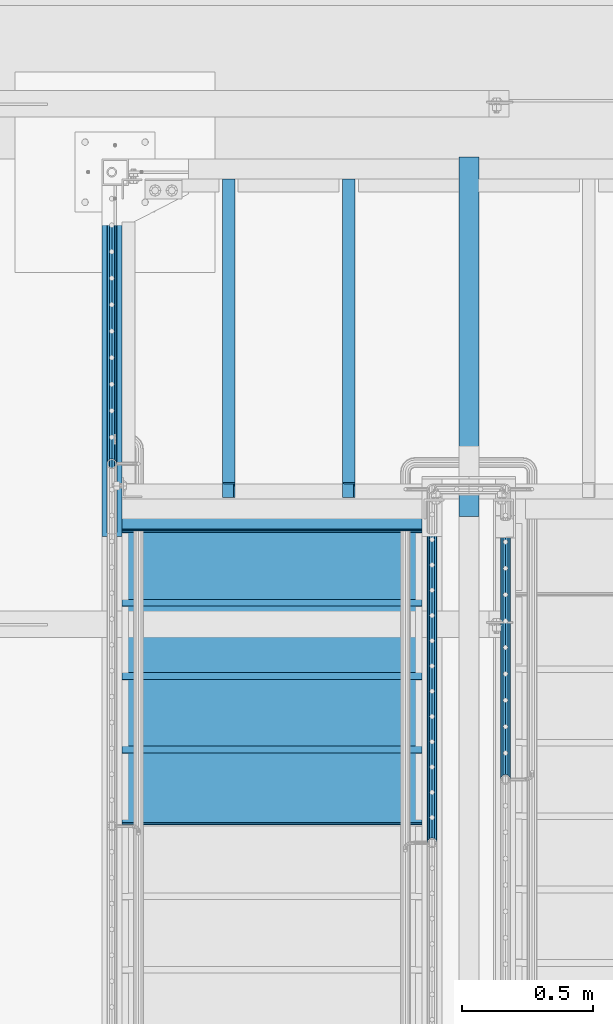
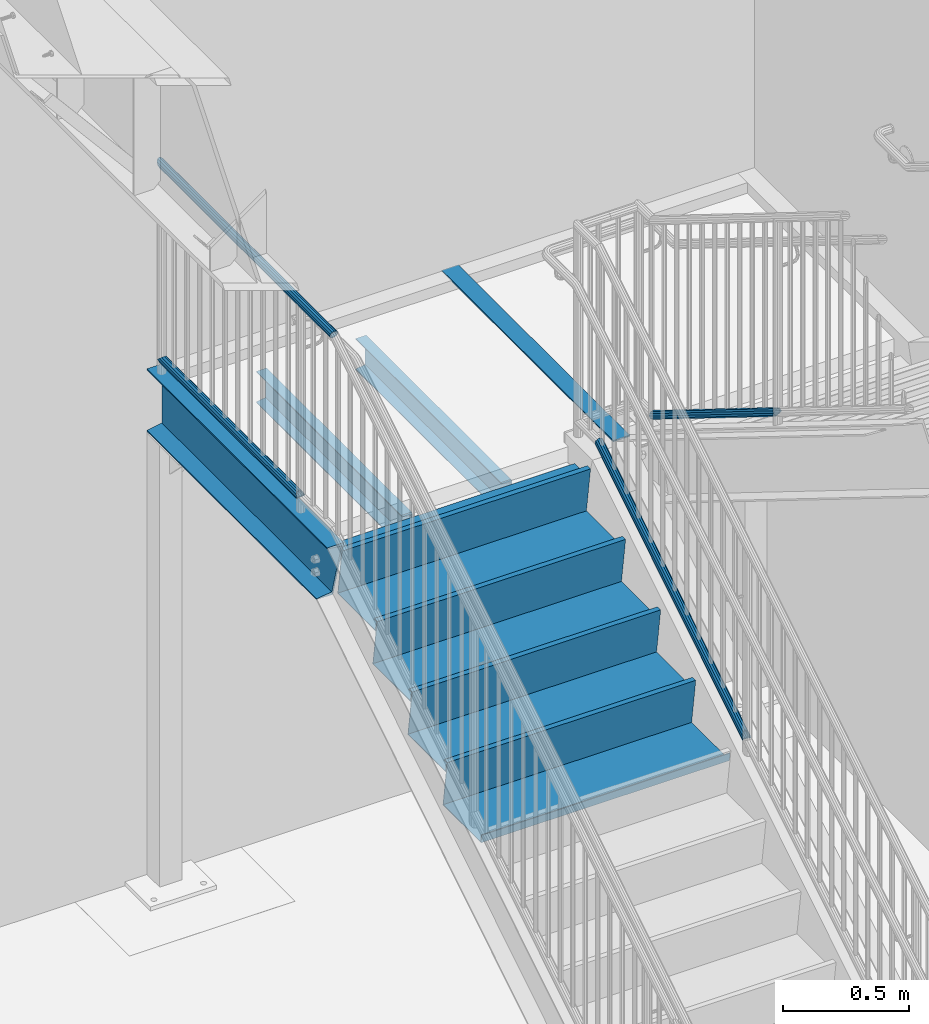
# One storey, part 1092 of 1763: 11 beams, 2 members, 6 elements without a shape of their own.
"""IFC2X3 building model written with IfcOpenShell, lengths in millimetres."""

import ifcopenshell
import ifcopenshell.guid

model = None  # the IFC model being written
_history = None  # IfcOwnerHistory: only IFC2X3 demands one
_inside = {}  # id of a spatial element -> (the spatial element, [elements in it])
_under = {}  # id of a project, library or spatial element -> (it, [spatial elements below it])
_declared = {}  # id of a project -> (the project, [libraries it declares])
_typed = {}  # id of a type object -> (the type object, [elements of that type])
_made_of = {}  # id of a material, layer set ... -> (it, [elements and type objects made of it])


def new_model(schema):
    """Start an empty IFC model of exactly this schema.

    Asked for "IFC4X3", IfcOpenShell would pick the latest addendum, in which some entities
    have other attributes; the version numbers below select the first issue.
    IFC2X3 requires an IfcOwnerHistory on every rooted entity: one is made here for all.
    """
    global model, _history
    if schema == "IFC4X3":
        model = ifcopenshell.file(schema_version=(4, 3, 0, 0))
    else:
        model = ifcopenshell.file(schema=schema)
    _inside.clear()
    _under.clear()
    _declared.clear()
    _typed.clear()
    _made_of.clear()
    _history = None
    if model.schema == "IFC2X3":
        org = make("IfcOrganization", Name="unknown")
        user = make(
            "IfcPersonAndOrganization",
            ThePerson=make("IfcPerson", FamilyName="unknown"),
            TheOrganization=org,
        )
        app = make(
            "IfcApplication",
            ApplicationDeveloper=org,
            Version="unknown",
            ApplicationFullName="unknown",
            ApplicationIdentifier="unknown",
        )
        _history = make(
            "IfcOwnerHistory",
            OwningUser=user,
            OwningApplication=app,
            ChangeAction="ADDED",
            CreationDate=0,
        )
    return model


def make(cls, **values):
    """One entity of the class cls with the attributes given. An attribute that is None is left unset."""
    return model.create_entity(
        cls, **{name: value for name, value in values.items() if value is not None}
    )


def rooted(cls, **values):
    """An entity with a GlobalId (a new one), such as an element, a storey or a relation."""
    return make(cls, GlobalId=ifcopenshell.guid.new(), OwnerHistory=_history, **values)


def si_unit(unit_type, name, prefix=None):
    """IfcSIUnit, for example si_unit("LENGTHUNIT", "METRE", prefix="MILLI")."""
    return make("IfcSIUnit", UnitType=unit_type, Prefix=prefix, Name=name)


def assignment(units):
    """IfcUnitAssignment: the units of a project."""
    return None if units is None else make("IfcUnitAssignment", Units=units)


def point(xyz):
    """IfcCartesianPoint."""
    return None if xyz is None else make("IfcCartesianPoint", Coordinates=xyz)


def direction(xyz):
    """IfcDirection."""
    return None if xyz is None else make("IfcDirection", DirectionRatios=xyz)


def frame(location, z_axis=None, x_axis=None):
    """IfcAxis2Placement3D, a coordinate frame: its origin and axes. An axis left out is left unset."""
    return make(
        "IfcAxis2Placement3D",
        Location=point(location),
        Axis=direction(z_axis),
        RefDirection=direction(x_axis),
    )


def origin_with_axes():
    """The frame at (0, 0, 0) with the z axis (0, 0, 1) and the x axis (1, 0, 0) written out."""
    return frame((0.0, 0.0, 0.0), z_axis=(0.0, 0.0, 1.0), x_axis=(1.0, 0.0, 0.0))


def place(relative_to, where):
    """IfcLocalPlacement: puts the frame where relative to a parent placement (None: the world)."""
    return make(
        "IfcLocalPlacement", PlacementRelTo=relative_to, RelativePlacement=where
    )


def context(
    kind, dimensions, precision=None, world=None, true_north=None, identifier=None
):
    """IfcGeometricRepresentationContext, for example the 3D "Model" context."""
    return make(
        "IfcGeometricRepresentationContext",
        ContextIdentifier=identifier,
        ContextType=kind,
        CoordinateSpaceDimension=dimensions,
        Precision=precision,
        WorldCoordinateSystem=world,
        TrueNorth=true_north,
    )


def subcontext(parent, identifier, kind, view, scale=None):
    """IfcGeometricRepresentationSubContext, for example "Body" below "Model"."""
    return make(
        "IfcGeometricRepresentationSubContext",
        ContextIdentifier=identifier,
        ContextType=kind,
        ParentContext=parent,
        TargetScale=scale,
        TargetView=view,
    )


def project(units=None, contexts=None):
    """IfcProject with its units and contexts."""
    return rooted(
        "IfcProject",
        Name="project",
        RepresentationContexts=contexts,
        UnitsInContext=assignment(units),
    )


def spatial(cls, under=None, at=None, **own):
    """A site, building, storey or space (cls), placed at a placement, below another one or the project."""
    s = rooted(cls, ObjectPlacement=at, **own)
    if under is not None:
        _under.setdefault(under.id(), (under, []))[1].append(s)
    return s


def faces_of(points, faces, orient=None, outer=None):
    """IfcFace entities. A face is a list of loops; a loop is a list of indices into points, from 0.

    orient and outer hold one flag for each loop. By default every Orientation is true, the
    first loop of a face is its IfcFaceOuterBound and the others are IfcFaceBound.
    """
    made = []
    for i, loops in enumerate(faces):
        bounds = []
        for j, loop in enumerate(loops):
            is_outer = j == 0 if outer is None else outer[i][j]
            bounds.append(
                make(
                    "IfcFaceOuterBound" if is_outer else "IfcFaceBound",
                    Bound=make("IfcPolyLoop", Polygon=[points[k] for k in loop]),
                    Orientation=True if orient is None else orient[i][j],
                )
            )
        made.append(make("IfcFace", Bounds=bounds))
    return made


def faceted_brep(points, faces, orient=None, outer=None, voids=None):
    """IfcFacetedBrep: a solid bounded by flat faces; with voids (closed shells), ...WithVoids."""
    shared = [point(p) for p in points]
    hull = make("IfcClosedShell", CfsFaces=faces_of(shared, faces, orient, outer))
    if voids is None:
        return make("IfcFacetedBrep", Outer=hull)
    return make(
        "IfcFacetedBrepWithVoids",
        Outer=hull,
        Voids=[
            make(cls, CfsFaces=faces_of(shared, fs, o, b)) for cls, fs, o, b in voids
        ],
    )


def shape(context_of_items, identifier, shape_type, items):
    """IfcShapeRepresentation: the items that make up one representation, for example the "Body"."""
    return make(
        "IfcShapeRepresentation",
        ContextOfItems=context_of_items,
        RepresentationIdentifier=identifier,
        RepresentationType=shape_type,
        Items=items,
    )


def material(Name=None, Category=None):
    """IfcMaterial."""
    return make("IfcMaterial", Name=Name, Category=Category)


def made_of(thing, what):
    """Note that an element or type object is made of a material, layer set ...; save() writes the relation."""
    if what is not None:
        _made_of.setdefault(what.id(), (what, []))[1].append(thing)
    return thing


def type_object(cls, material=None, **own):
    """A type object (cls), such as IfcWallType, which elements share."""
    return made_of(rooted(cls, **own), material)


def element(
    cls,
    number,
    at=None,
    inside=None,
    cuts=None,
    type_object=None,
    material=None,
    context=None,
    identifier="Body",
    shape_type=None,
    held_by="IfcProductDefinitionShape",
    body=None,
    shapes=None,
    **own,
):
    """One element of the class cls, such as IfcWall. Its Tag is "e" and its number.

    at: its placement. inside: the storey or other place that contains it. cuts: it is an
    opening in that element (IfcRelVoidsElement). A single representation is given by context,
    identifier, shape_type and body (its items); several are given by shapes. held_by: the class
    of the entity that holds the representations. save() writes the other relations.
    """
    e = rooted(cls, Tag="e%d" % number, ObjectPlacement=at, **own)
    if body is not None:
        shapes = [shape(context, identifier, shape_type, body)]
    if shapes is not None:
        e.Representation = make(held_by, Representations=shapes)
    if inside is not None:
        _inside.setdefault(inside.id(), (inside, []))[1].append(e)
    if cuts is not None:
        rooted(
            "IfcRelVoidsElement", RelatingBuildingElement=cuts, RelatedOpeningElement=e
        )
    if type_object is not None:
        _typed.setdefault(type_object.id(), (type_object, []))[1].append(e)
    return made_of(e, material)


def aggregate(whole, parts):
    """IfcRelAggregates: a whole, such as a stair, and the parts it consists of."""
    return rooted("IfcRelAggregates", RelatingObject=whole, RelatedObjects=parts)


def save(model, path):
    """Write the relations noted so far, then the file.

    IfcRelAggregates (storeys below a building ...), IfcRelContainedInSpatialStructure (elements
    in a storey), IfcRelDefinesByType, IfcRelAssociatesMaterial and IfcRelDeclares: one each for
    every whole, place, type object, material and project.
    """
    for whole, parts in _under.values():
        aggregate(whole, parts)
    for where, things in _inside.values():
        rooted(
            "IfcRelContainedInSpatialStructure",
            RelatedElements=things,
            RelatingStructure=where,
        )
    for kind, things in _typed.values():
        rooted("IfcRelDefinesByType", RelatedObjects=things, RelatingType=kind)
    for what, things in _made_of.values():
        rooted("IfcRelAssociatesMaterial", RelatedObjects=things, RelatingMaterial=what)
    for by, libraries in _declared.values():
        rooted("IfcRelDeclares", RelatingContext=by, RelatedDefinitions=libraries)
    model.write(path)


model = new_model("IFC2X3")

# Units and contexts
model_context = context("Model", 3, precision=1e-05, world=origin_with_axes())
body_context = subcontext(model_context, "Body", "Model", "MODEL_VIEW")
ifc_project = project(units=[si_unit("LENGTHUNIT", "METRE", prefix="MILLI"), si_unit("AREAUNIT", "SQUARE_METRE"), si_unit("VOLUMEUNIT", "CUBIC_METRE"), si_unit("MASSUNIT", "GRAM", prefix="KILO"), si_unit("TIMEUNIT", "SECOND"), si_unit("PLANEANGLEUNIT", "RADIAN"), si_unit("SOLIDANGLEUNIT", "STERADIAN"), si_unit("THERMODYNAMICTEMPERATUREUNIT", "DEGREE_CELSIUS"), si_unit("LUMINOUSINTENSITYUNIT", "LUMEN")], contexts=[model_context])

# Site, building, storey
site_placement = place(None, origin_with_axes())
site = spatial("IfcSite", under=ifc_project, at=site_placement, CompositionType="ELEMENT")
building_placement = place(site_placement, origin_with_axes())
building = spatial("IfcBuilding", under=site, at=building_placement, Name="Undefined", CompositionType="ELEMENT")
storey_placement = place(building_placement, origin_with_axes())
storey = spatial("IfcBuildingStorey", under=building, at=storey_placement, Name="Undefined", CompositionType="ELEMENT", Elevation=0.0)

# Assembly, beams
assembly_1_placement = place(storey_placement, origin_with_axes())
assembly_1 = element("IfcElementAssembly", 1, at=assembly_1_placement, inside=storey, Name="RAIL", AssemblyPlace="NOTDEFINED", PredefinedType="RIGID_FRAME")
ifc_material_1 = material(Name="STEEL/A513")
beam_type_1 = type_object("IfcBeamType", PredefinedType="NOTDEFINED")
beam_1_placement = place(assembly_1_placement, frame((-86778.5372736934, 36189.9200003705, 2852.7375000151), z_axis=(0.0, 0.0, 1.0), x_axis=(0.0, 1.0, 0.0)))
beam_1 = element("IfcBeam", 2, at=beam_1_placement, type_object=beam_type_1, material=ifc_material_1, Name="RAIL", context=body_context, shape_type="Brep", body=[
    faceted_brep([(1093.48221605259, -9.52499999999418, 16.4977839420935), (1093.48221605259, -9.52500000015425, 11.4667123797954), (1092.98878761468, -7.68349999999919, 13.3082123799554), (1090.92999999467, 0.0, 15.3670000000002), (1090.92999999467, 0.0, 19.0500000000002), (1092.98878761476, 7.68349999999919, 13.3082123799554), (1093.48221605259, 9.52499999983411, 11.4667123801155), (1093.48221605259, 9.52499999999418, 16.4977839420935), (1109.98, 19.0500000000029, 0.0), (1100.45499999468, 16.4977839420899, 9.52500000000009), (1100.45499999468, 16.4977839420899, -9.52500000000009), (1097.2654284327, 13.3082123799541, 7.68350000000009), (1099.32421605274, 15.3669999999984, 0.0), (1097.2654284327, 13.3082123799541, -7.68350000000009), (1093.48221605259, 9.52499999983411, -11.4667123801155), (1093.48221605259, 9.52499999999418, -16.4977839420935), (1092.98878761476, 7.68349999999919, -13.3082123799554), (1090.92999999467, 0.0, -15.3670000000002), (1090.92999999467, 0.0, -19.0500000000002), (1093.48221605259, -9.52500000015425, -11.4667123797954), (1093.48221605259, -9.52499999999418, -16.4977839420935), (1092.98878761468, -7.68349999999919, -13.3082123799554), (1109.97999999468, -19.050000000163, 0.0), (1100.45499999468, -16.4977839420899, -9.52500000000009), (1100.45499999468, -16.4977839420899, 9.52500000000009), (1097.26542843238, -13.3082123799541, -7.68350000000009), (1099.32421605242, -15.3669999999984, 0.0), (1097.26542843238, -13.3082123799541, 7.68350000000009), (9.52499999467545, -16.4977839420899, -9.52500000000009), (16.4977839367712, -9.52499999999418, -16.4977839420935), (0.0, 19.0500000000029, 0.0), (9.52499999467545, 16.4977839420899, -9.52500000000009), (9.52500000096188, 16.4977839420899, 9.52500000000009), (16.4977839430576, 9.52499999999418, 16.4977839420935), (19.0500000009633, 0.0, 19.0500000000002), (16.4977839367712, 9.52499999999418, -16.4977839420935), (19.0499999946769, 0.0, -19.0500000000002), (19.0499999946769, 0.0, -15.3670000000002), (16.4977839367712, -9.52500000031432, -11.4667123796353), (16.9912123747126, -7.68349999999919, -13.3082123799554), (16.9912123745453, 7.68349999999919, -13.3082123799554), (16.4977839367712, 9.52499999967404, -11.4667123802756), (12.7145715564911, 13.3082123799541, -7.68350000000009), (10.6557839364468, 15.3669999999984, 0.0), (12.7145715564911, 13.3082123799541, 7.68350000000009), (16.4977839367712, 9.52499999967404, 11.4667123802756), (16.9912123745453, 7.68349999999919, 13.3082123799554), (19.0499999946769, -3.20142135024071e-10, 15.3670000000002), (16.9912123747126, -7.68349999999919, 13.3082123799554), (16.4977839367712, -9.52500000031432, 11.4667123796353), (16.4977839430576, -9.52499999999418, 16.4977839420935), (9.52500000096188, -16.4977839420899, 9.52500000000009), (0.0, -19.0500000000029, 0.0), (12.7145715571314, -13.3082123799541, 7.68350000000009), (10.6557839370871, -15.3669999999984, 0.0), (12.7145715571314, -13.3082123799541, -7.68350000000009)], [[[0, 1, 2, 3, 4]], [[4, 3, 5, 6, 7]], [[8, 9, 10]], [[7, 6, 11, 12, 13, 14, 15, 10, 9]], [[16, 17, 18, 15, 14]], [[19, 20, 18, 17, 21]], [[22, 23, 24]], [[24, 23, 20, 19, 25, 26, 27, 1, 0]], [[28, 29, 20, 23]], [[30, 31, 32]], [[33, 34, 4, 7]], [[32, 33, 7, 9]], [[30, 32, 9, 8]], [[31, 30, 8, 10]], [[35, 31, 10, 15]], [[36, 35, 15, 18]], [[29, 36, 18, 20]], [[37, 36, 29, 38, 39]], [[40, 41, 35, 36, 37]], [[32, 31, 35, 41, 42, 43, 44, 45, 33]], [[33, 45, 46, 47, 34]], [[34, 47, 48, 49, 50]], [[34, 50, 0, 4]], [[50, 51, 24, 0]], [[51, 52, 22, 24]], [[52, 28, 23, 22]], [[51, 28, 52]], [[50, 49, 53, 54, 55, 38, 29, 28, 51]], [[55, 54, 26, 25]], [[21, 39, 38, 55, 25, 19]], [[37, 39, 21, 17]], [[40, 37, 17, 16]], [[42, 41, 40, 16, 14, 13]], [[43, 42, 13, 12]], [[44, 43, 12, 11]], [[5, 46, 45, 44, 11, 6]], [[47, 46, 5, 3]], [[48, 47, 3, 2]], [[53, 49, 48, 2, 1, 27]], [[54, 53, 27, 26]]]),
])
beam_2_placement = place(assembly_1_placement, frame((-86778.5372736929, 37318.9500003693, 3798.8875000151), z_axis=(0.0, 0.0, -1.0), x_axis=(0.0, -1.0, 0.0)))
beam_2 = element("IfcBeam", 3, at=beam_2_placement, type_object=beam_type_1, material=ifc_material_1, Name="RAIL", context=body_context, shape_type="Brep", body=[
    faceted_brep([(19.0500000000029, -15.3670000000855, 0.0), (26.7334999735467, -13.3082123799541, 7.68350000000009), (1388.45977161881, -13.3082123799541, 7.68350000000009), (1390.65000208809, -15.3669999999984, 0.0), (32.3582123535016, -7.68349999999919, 13.3082123799554), (1386.85641163502, -7.68349999999919, 13.3082123799554), (34.4169999735459, 0.0, 15.3670000000002), (1386.26954114954, 0.0, 15.3670000000002), (32.3582123535016, 7.68349999999919, 13.3082123799554), (1386.85641163502, 7.68349999999919, 13.3082123799554), (26.7334999735467, 13.3082123799541, 7.68350000000009), (1388.45977161881, 13.3082123799541, 7.68350000000009), (19.0500000000029, 15.3669999999146, 0.0), (1390.65000208809, 15.3669999999984, 0.0), (11.3664999735483, 13.3082123799541, -7.68350000000009), (1392.84023255737, 13.3082123799541, -7.68350000000009), (5.74178759359347, 7.68349999999919, -13.3082123799554), (1394.44359254117, 7.68349999999919, -13.3082123799554), (3.68299997354916, 0.0, -15.3670000000002), (1395.03046302665, 0.0, -15.3670000000002), (5.74178759359347, -7.68349999999919, -13.3082123799554), (1394.44359254117, -7.68349999999919, -13.3082123799554), (11.3664999735483, -13.3082123799541, -7.68350000000009), (1392.84023255737, -13.3082123799541, -7.68350000000009), (19.0500000000029, -19.0500000000854, 0.0), (9.52499999467545, -16.4977839420899, -9.52500000000009), (1393.36516382687, -16.4977839420899, -9.52500000000009), (1390.65000208809, -19.0500000000029, 0.0), (2.55221603145037, -9.52499999999418, -16.4977839420935), (1395.35280017042, -9.52499999999418, -16.4977839420935), (1.45519152283669e-11, 1.81898940354586e-12, -19.0499999999993), (1396.08032556564, 0.0, -19.0500000000002), (2.55221603145037, 9.52499999999418, -16.4977839420935), (1395.35280017042, 9.52499999999418, -16.4977839420935), (9.52499999467545, 16.4977839420899, -9.52500000000009), (1393.36516382687, 16.4977839420899, -9.52500000000009), (19.0500000000029, 19.0499999999146, 0.0), (1390.65000208809, 19.0500000000029, 0.0), (28.574999973549, 16.4977839420899, 9.52500000000009), (1387.93484034931, 16.4977839420899, 9.52500000000009), (35.5477839156374, 9.52499999999418, 16.4977839420935), (1385.94720400577, 9.52499999999418, 16.4977839420935), (38.0999999735432, 0.0, 19.0500000000002), (1385.21967861054, 0.0, 19.0500000000002), (35.5477839156374, -9.52499999999418, 16.4977839420935), (1385.94720400577, -9.52499999999418, 16.4977839420935), (28.574999973549, -16.4977839420899, 9.52500000000009), (1387.93484034931, -16.4977839420899, 9.52500000000009)], [[[0, 1, 2, 3]], [[1, 4, 5, 2]], [[4, 6, 7, 5]], [[6, 8, 9, 7]], [[8, 10, 11, 9]], [[10, 12, 13, 11]], [[12, 14, 15, 13]], [[14, 16, 17, 15]], [[16, 18, 19, 17]], [[18, 20, 21, 19]], [[20, 22, 23, 21]], [[22, 0, 3, 23]], [[24, 25, 26, 27]], [[25, 28, 29, 26]], [[28, 30, 31, 29]], [[30, 32, 33, 31]], [[32, 34, 35, 33]], [[34, 36, 37, 35]], [[36, 38, 39, 37]], [[38, 40, 41, 39]], [[40, 42, 43, 41]], [[42, 44, 45, 43]], [[44, 46, 47, 45]], [[46, 24, 27, 47]], [[29, 31, 33, 35, 37, 39, 41, 43, 45, 47, 27, 26], [5, 7, 9, 11, 13, 15, 17, 19, 21, 23, 3, 2]], [[46, 44, 42, 40, 38, 36, 34, 32, 30, 28, 25, 24], [22, 20, 18, 16, 14, 12, 10, 8, 6, 4, 1, 0]]]),
])
aggregate(assembly_1, [beam_1, beam_2])

# Assembly, beam
assembly_2_placement = place(storey_placement, origin_with_axes())
assembly_2 = element("IfcElementAssembly", 4, at=assembly_2_placement, inside=storey, Name="STRINGER", AssemblyPlace="NOTDEFINED", PredefinedType="RIGID_FRAME")
ifc_material_2 = material(Name="STEEL/A36")
beam_type_2 = type_object("IfcBeamType", Name="C12X20.7", PredefinedType="NOTDEFINED")
beam_3_placement = place(assembly_2_placement, frame((-86778.537273735, 37350.6999999912, 2630.48749999325), z_axis=(0.0, 0.0, 1.0), x_axis=(0.0, -1.0, 0.0)))
beam_3 = element("IfcBeam", 5, at=beam_3_placement, type_object=beam_type_2, material=ifc_material_2, Name="STRINGER", ObjectType="C12X20.7", context=body_context, shape_type="Brep", body=[
    faceted_brep([(0.0, 38.1000000000004, -152.4), (0.0, 38.1000000000004, 152.4), (1436.88086402786, 38.1000000000058, 152.4), (1349.99567983106, 38.1000000000058, -152.4), (0.0, -38.1000000000004, 152.4), (1436.88086402786, -38.1000000000058, 152.4), (0.0, -38.1000000000004, 146.04746), (1435.07003198056, -38.1000000000058, 146.04746), (0.0, 30.1625000000004, 134.6749275), (1431.82821905061, 30.1625000000058, 134.6749275), (0.0, 30.1625000000004, -134.6749275), (1355.0483248083, 30.1625000000058, -134.6749275), (0.0, -38.1000000000004, -146.04746), (1351.80651187836, -38.1000000000058, -146.04746), (0.0, -38.1000000000004, -152.4), (1349.99567983106, -38.1000000000058, -152.4)], [[[0, 1, 2, 3]], [[1, 4, 5, 2]], [[4, 6, 7, 5]], [[6, 8, 9, 7]], [[8, 10, 11, 9]], [[10, 12, 13, 11]], [[12, 14, 15, 13]], [[14, 0, 3, 15]], [[5, 7, 9, 11, 13, 15, 3, 2]], [[14, 12, 10, 8, 6, 4, 1, 0]]]),
])

# Assembly, beams
assembly_3_placement = place(storey_placement, origin_with_axes())
assembly_3 = element("IfcElementAssembly", 6, at=assembly_3_placement, inside=storey, Name="STRINGER", AssemblyPlace="NOTDEFINED", PredefinedType="RIGID_FRAME")
beam_type_3 = type_object("IfcBeamType", Name="C6X8.2", PredefinedType="NOTDEFINED")
beam_4_placement = place(assembly_3_placement, frame((-86334.1034190285, 36061.6500002742, 2579.68749999999), z_axis=(0.0, 0.0, -1.0), x_axis=(0.0, 1.0, 0.0)))
beam_4 = element("IfcBeam", 7, at=beam_4_placement, type_object=beam_type_3, material=ifc_material_2, Name="BEAM", ObjectType="C6X8.2", context=body_context, shape_type="Brep", body=[
    faceted_brep([(57.1500002860994, -23.8125, -76.2000000013695), (53.1796626072537, -23.8125, -72.2296624999999), (50.800000858304, -9.52881209726911, -69.8500000954054), (50.800000858304, 23.8125, -69.8500000954054), (57.1500002860994, 23.8125, -76.1999999999998), (0.0, -23.8125, 72.2296624999999), (0.0, 19.0500000000029, 65.0887699999998), (1212.84999972743, 19.0500000000029, 65.0887699999998), (1212.84999972743, -23.8125, 72.2296624999999), (0.0, -23.8125, 76.1999999999998), (1212.84999972743, -23.8125, 76.1999999999998), (0.0, 23.8125, 76.1999999999998), (1212.84999972743, 23.8125, 76.1999999999998), (0.0, 23.8125, -50.8000003814695), (0.0, 19.0500000000029, -50.8000003814695), (38.1000010490388, 23.8125, -50.8000003814695), (38.1000010490388, 19.0500000000029, -50.8000003814695), (42.9600805670852, 23.8125, -51.7667303040575), (42.9600805670852, 19.0500000000029, -51.7667303040575), (47.0802570352389, 23.8125, -54.5197442045355), (47.0802570352389, 19.0500000000029, -54.5197442045355), (49.8332709357128, 23.8125, -58.6399206726892), (49.8332709357128, 19.0500000000029, -58.6399206726892), (50.800000858304, 23.8125, -63.5000001907347), (50.800000858304, 19.0500000000029, -63.5000001907347), (1212.84999972743, 19.0500000000029, -65.0887699999998), (50.800000858304, 19.0500000000029, -65.0887699999998), (1212.84999972743, -23.8125, -72.2296624999999), (1212.84999972743, -23.8125, -76.1999999999998), (1212.84999972743, 23.8125, -76.1999999999998)], [[[0, 1, 2, 3, 4]], [[5, 6, 7, 8]], [[9, 5, 8, 10]], [[11, 9, 10, 12]], [[6, 5, 9, 11, 13, 14]], [[14, 13, 15, 16]], [[16, 15, 17, 18]], [[18, 17, 19, 20]], [[20, 19, 21, 22]], [[22, 21, 23, 24]], [[25, 7, 6, 14, 16, 18, 20, 22, 24, 26]], [[10, 8, 7, 25, 27, 28, 29, 12]], [[29, 28, 0, 4]], [[23, 21, 19, 17, 15, 13, 11, 12, 29, 4, 3]], [[26, 24, 23, 3, 2]], [[27, 25, 26, 2, 1]], [[28, 27, 1, 0]]]),
])
beam_5_placement = place(assembly_3_placement, frame((-85876.7711273703, 36061.6500002742, 2579.68749999999), z_axis=(0.0, 0.0, -1.0), x_axis=(0.0, 1.0, 0.0)))
beam_5 = element("IfcBeam", 8, at=beam_5_placement, type_object=beam_type_3, material=ifc_material_2, Name="BEAM", ObjectType="C6X8.2", context=body_context, shape_type="Brep", body=[
    faceted_brep([(57.1500002860994, -23.8125, -76.2000000013695), (53.1796626072537, -23.8125, -72.2296624999999), (50.800000858304, -9.52881209726911, -69.8500000954054), (50.800000858304, 23.8125, -69.8500000954054), (57.1500002860994, 23.8125, -76.1999999999998), (0.0, -23.8125, 72.2296624999999), (0.0, 19.0500000000029, 65.0887699999998), (1212.84999972743, 19.0500000000029, 65.0887699999998), (1212.84999972743, -23.8125, 72.2296624999999), (0.0, -23.8125, 76.1999999999998), (1212.84999972743, -23.8125, 76.1999999999998), (0.0, 23.8125, 76.1999999999998), (1212.84999972743, 23.8125, 76.1999999999998), (0.0, 23.8125, -50.8000003814695), (0.0, 19.0500000000029, -50.8000003814695), (38.1000010490388, 23.8125, -50.8000003814695), (38.1000010490388, 19.0500000000029, -50.8000003814695), (42.9600805670852, 23.8125, -51.7667303040575), (42.9600805670852, 19.0500000000029, -51.7667303040575), (47.0802570352389, 23.8125, -54.5197442045355), (47.0802570352389, 19.0500000000029, -54.5197442045355), (49.8332709357128, 23.8125, -58.6399206726892), (49.8332709357128, 19.0500000000029, -58.6399206726892), (50.800000858304, 23.8125, -63.5000001907347), (50.800000858304, 19.0500000000029, -63.5000001907347), (1212.84999972743, 19.0500000000029, -65.0887699999998), (50.800000858304, 19.0500000000029, -65.0887699999998), (1212.84999972743, -23.8125, -72.2296624999999), (1212.84999972743, -23.8125, -76.1999999999998), (1212.84999972743, 23.8125, -76.1999999999998)], [[[0, 1, 2, 3, 4]], [[5, 6, 7, 8]], [[9, 5, 8, 10]], [[11, 9, 10, 12]], [[6, 5, 9, 11, 13, 14]], [[14, 13, 15, 16]], [[16, 15, 17, 18]], [[18, 17, 19, 20]], [[20, 19, 21, 22]], [[22, 21, 23, 24]], [[25, 7, 6, 14, 16, 18, 20, 22, 24, 26]], [[10, 8, 7, 25, 27, 28, 29, 12]], [[29, 28, 0, 4]], [[23, 21, 19, 17, 15, 13, 11, 12, 29, 4, 3]], [[26, 24, 23, 3, 2]], [[27, 25, 26, 2, 1]], [[28, 27, 1, 0]]]),
])
aggregate(assembly_3, [beam_4, beam_5])

# Assembly, beam
assembly_4_placement = place(storey_placement, origin_with_axes())
assembly_4 = element("IfcElementAssembly", 9, at=assembly_4_placement, inside=storey, Name="ref.", AssemblyPlace="NOTDEFINED", PredefinedType="NOTDEFINED")
ifc_material_3 = material()
beam_type_4 = type_object("IfcBeamType", PredefinedType="NOTDEFINED")
beam_6_placement = place(assembly_4_placement, frame((-85419.6372736932, 37357.0499999999, 2779.7125000151), z_axis=(1.0, 0.0, 0.0), x_axis=(0.0, -1.0, 0.0)))
beam_6 = element("IfcBeam", 10, at=beam_6_placement, type_object=beam_type_4, material=ifc_material_3, Name="ref.", context=body_context, shape_type="Brep", body=[
    faceted_brep([(0.0, 3.17500000000018, -38.0999999999985), (0.0, 3.17500000000018, 38.0999999999985), (1367.03086409371, 3.17500000000018, 38.1000000000058), (1367.03086409371, 3.17500000000018, -38.1000000000058), (0.0, -3.17500000000018, 38.0999999999985), (1367.03086409371, -3.17500000000018, 38.1000000000058), (0.0, -3.17500000000018, -38.0999999999985), (1367.03086409371, -3.17500000000018, -38.1000000000058)], [[[0, 1, 2, 3]], [[1, 4, 5, 2]], [[4, 6, 7, 5]], [[6, 0, 3, 7]], [[5, 7, 3, 2]], [[6, 4, 1, 0]]]),
])
aggregate(assembly_4, [beam_6])

# Assembly, member
assembly_5_placement = place(storey_placement, origin_with_axes())
assembly_5 = element("IfcElementAssembly", 11, at=assembly_5_placement, inside=storey, Name="RAIL", AssemblyPlace="NOTDEFINED", PredefinedType="RIGID_FRAME")
member_type = type_object("IfcMemberType", PredefinedType="NOTDEFINED")
member_1_placement = place(assembly_5_placement, frame((-85559.3372736672, 34747.2000003711, 2119.82285597248), z_axis=(0.0, -0.527268387919125, 0.849698797869673), x_axis=(0.0, 0.849698797869672, 0.527268387919126)))
member_1 = element("IfcMember", 12, at=member_1_placement, type_object=member_type, material=ifc_material_1, Name="RAIL", context=body_context, shape_type="Brep", body=[
    faceted_brep([(0.0, 19.0500000000029, 0.0), (5.29925264853227, 16.4977839420899, -9.52499999999418), (17.1204566035267, 16.4977839420899, 9.5249999999578), (17.1204566035267, -16.4977839420899, 9.5249999999578), (5.29925264853227, -16.4977839420899, -9.52499999999418), (0.0, -19.0500000000029, 0.0), (29.6535006860868, -9.52499999999418, 16.4977839420208), (26.5315414871147, -9.5249999739608, 11.4667124059306), (19.7315074910439, -13.3082123799541, 7.68349999995917), (12.5406602238363, -15.3669999999984, -1.81898940354586e-11), (10.195736300775, -13.3082123799541, -7.68349999999919), (12.3005340283707, -9.5249999739608, -11.4667124059888), (9.17857482939507, -9.52499999999418, -16.497783942079), (12.8839380616882, 0.0, -15.3669999999911), (10.5985052970609, 0.0, -19.0499999999811), (11.7385274769949, -7.68349999999919, -13.3082123799504), (11.7385274934168, 7.68349999999919, -13.3082123799504), (12.3005340606833, 9.52500002602756, -11.466712353922), (9.17857482939507, 9.52499999999418, -16.497783942079), (10.1957363620568, 13.3082123799541, -7.68350000000282), (12.5406602851217, 15.3669999999984, -1.81898940354586e-11), (19.7315075523256, 13.3082123799541, 7.68349999995917), (26.5315414548058, 9.52500002602756, 11.4667123538638), (29.6535006860868, 9.52499999999418, 16.4977839420208), (28.2549676843155, 7.68349999999919, 13.3082123798886), (31.9554804424188, 2.60333763435483e-08, 15.3669999999256), (34.240913207057, 2.60333763435483e-08, 19.0499999999156), (28.2549676678937, -7.68349999999919, 13.3082123798922), (1390.02197142436, -19.0500000000029, -1.77897163666785e-09), (1392.7371331531, -16.4977839420899, 9.52499999820066), (1394.72476948931, -9.52499999999418, 16.4977839402818), (1395.45229488185, 0.0, 19.0499999981803), (1385.31917335941, -9.52499999999418, -16.4977839438361), (1387.30680969561, -16.4977839420899, -9.5250000017586), (1384.59164796687, 0.0, -19.0500000017382), (1385.31917335941, 9.52499999999418, -16.4977839438361), (1387.30680969561, 16.4977839420899, -9.5250000017586), (1390.02197142436, 19.0500000000029, -1.77897163666785e-09), (1392.7371331531, 16.4977839420899, 9.52499999820066), (1394.72476948931, 9.52499999999418, 16.4977839402818), (1393.81556186342, -7.68349999999919, 13.308212378146), (1394.40243234673, 0.0, 15.3669999981903), (1393.81556186342, 7.68349999999919, 13.308212378146), (1392.21220188554, 13.3082123799541, 7.68349999820566), (1390.02197142436, 15.3669999999984, -1.77897163666785e-09), (1387.83174096317, 13.3082123799541, -7.68350000175997), (1386.2283809853, 7.68349999999919, -13.3082123817076), (1385.64151050198, 0.0, -15.367000001741), (1386.2283809853, -7.68349999999919, -13.3082123817076), (1387.83174096317, -13.3082123799541, -7.68350000175997), (1390.02197142436, -15.3669999999984, -1.77897163666785e-09), (1392.21220188554, -13.3082123799541, 7.68349999820566)], [[[0, 1, 2]], [[3, 4, 5]], [[6, 7, 8, 9, 10, 11, 12, 4, 3]], [[13, 14, 12, 11, 15]], [[16, 17, 18, 14, 13]], [[2, 1, 18, 17, 19, 20, 21, 22, 23]], [[23, 22, 24, 25, 26]], [[26, 25, 27, 7, 6]], [[28, 29, 3, 5]], [[29, 30, 6, 3]], [[30, 31, 26, 6]], [[32, 33, 4, 12]], [[34, 32, 12, 14]], [[35, 34, 14, 18]], [[36, 35, 18, 1]], [[37, 36, 1, 0]], [[38, 37, 0, 2]], [[39, 38, 2, 23]], [[31, 39, 23, 26]], [[33, 28, 5, 4]], [[32, 34, 35, 36, 37, 38, 39, 31, 30, 29, 28, 33], [40, 41, 42, 43, 44, 45, 46, 47, 48, 49, 50, 51]], [[42, 41, 25, 24]], [[21, 43, 42, 24, 22]], [[44, 43, 21, 20]], [[45, 44, 20, 19]], [[46, 45, 19, 17, 16]], [[47, 46, 16, 13]], [[48, 47, 13, 15]], [[49, 48, 15, 11, 10]], [[50, 49, 10, 9]], [[51, 50, 9, 8]], [[40, 51, 8, 7, 27]], [[41, 40, 27, 25]]]),
])
aggregate(assembly_5, [member_1])

assembly_6_placement = place(storey_placement, origin_with_axes())
assembly_6 = element("IfcElementAssembly", 13, at=assembly_6_placement, inside=storey, Name="RAIL", AssemblyPlace="NOTDEFINED", PredefinedType="RIGID_FRAME")
member_2_placement = place(assembly_6_placement, frame((-85279.8721005488, 35979.1000012715, 2852.73750001514), z_axis=(0.0, 0.527450977296466, 0.849585467477524), x_axis=(0.0, -0.849585467029397, 0.527450978018281)))
member_2 = element("IfcMember", 14, at=member_2_placement, type_object=member_type, material=ifc_material_1, Name="RAIL", context=body_context, shape_type="Brep", body=[
    faceted_brep([(1156.8041439415, -9.52499999999418, 16.4977839428502), (1153.68068701601, -9.52499999976135, 11.4667123809522), (1154.24316431273, -7.68349999999919, 13.308212380718), (1153.09804340917, 0.0, 15.3670000007551), (1155.38457257399, 0.0, 19.0500000007487), (1154.24316431256, 7.68349999999919, 13.308212380718), (1153.68068701572, 9.52500000022701, 11.4667123804866), (1156.8041439415, 9.52499999999418, 16.4977839428502), (1165.98039826308, 19.0500000000029, 3.38332029059529e-10), (1160.68248504249, 16.4977839420899, 9.52500000076907), (1148.85561005207, 16.4977839420899, -9.52499999920474), (1155.78495242682, 13.3082123799541, 7.6835000007668), (1153.43806439691, 15.3669999999984, 7.78527464717627e-10), (1146.24460660126, 13.3082123799541, -7.68349999921338), (1139.4428524891, 9.52500000022701, -11.4667123789368), (1136.31939556332, 9.52499999999418, -16.4977839413004), (1137.71880062092, 7.68349999999919, -13.308212379161), (1134.01735175796, 0.0, -15.3669999992053), (1131.73082259314, 0.0, -19.0499999992026), (1139.44285248881, -9.52499999976135, -11.4667123794025), (1136.31939556332, -9.52499999999418, -16.4977839413004), (1137.71880062108, -7.68349999999919, -13.308212379161), (1165.98039826308, -19.0500000000029, 3.38332029059529e-10), (1148.85561005207, -16.4977839420899, -9.52499999920474), (1160.68248504249, -16.4977839420899, 9.52500000076907), (1146.24460660185, -13.3082123799541, -7.68349999920974), (1153.43806439749, -15.3669999999984, 7.82165443524718e-10), (1155.78495242741, -13.3082123799541, 7.68350000077407), (-2.71626829489105, -16.4977839420899, -9.52499999998327), (-4.70471477459068, -9.52499999999418, -16.4977839420681), (-5.4325367002275, 0.0, -19.0499999999702), (-4.70471477459068, 9.52499999999418, -16.4977839420681), (-2.71626829489105, 16.4977839420899, -9.52499999998327), (0.0, 19.0500000000029, 0.0), (2.71626851578549, 16.4977839420899, 9.52499999999054), (4.70471499548876, 9.52499999999418, 16.4977839420717), (5.43253692112557, 0.0, 19.0499999999738), (4.70471499548876, -9.52499999999418, 16.4977839420717), (2.71626851578549, -16.4977839420899, 9.52499999999054), (0.0, -19.0500000000029, 0.0), (-2.19112306985699, -13.3082123799541, -7.68349999998827), (-3.79513656348718, -7.68349999999919, -13.3082123799322), (-4.38224625016301, 0.0, -15.3669999999765), (-3.79513656348718, 7.68349999999919, -13.3082123799322), (-2.19112306985699, 13.3082123799541, -7.68349999998827), (4.71409293822944e-08, 15.3669999999984, 0.0), (2.19112329075506, 13.3082123799541, 7.68349999999191), (3.79513678437797, 7.68349999999919, 13.3082123799395), (4.38224647105744, 0.0, 15.3669999999802), (3.79513678437797, -7.68349999999919, 13.3082123799395), (2.19112329075506, -13.3082123799541, 7.68349999999191), (4.71409293822944e-08, -15.3669999999984, 0.0)], [[[0, 1, 2, 3, 4]], [[4, 3, 5, 6, 7]], [[8, 9, 10]], [[7, 6, 11, 12, 13, 14, 15, 10, 9]], [[16, 17, 18, 15, 14]], [[19, 20, 18, 17, 21]], [[22, 23, 24]], [[24, 23, 20, 19, 25, 26, 27, 1, 0]], [[28, 29, 20, 23]], [[29, 30, 18, 20]], [[30, 31, 15, 18]], [[31, 32, 10, 15]], [[32, 33, 8, 10]], [[33, 34, 9, 8]], [[34, 35, 7, 9]], [[35, 36, 4, 7]], [[36, 37, 0, 4]], [[37, 38, 24, 0]], [[38, 39, 22, 24]], [[39, 28, 23, 22]], [[38, 37, 36, 35, 34, 33, 32, 31, 30, 29, 28, 39], [40, 41, 42, 43, 44, 45, 46, 47, 48, 49, 50, 51]], [[51, 50, 27, 26]], [[40, 51, 26, 25]], [[21, 41, 40, 25, 19]], [[42, 41, 21, 17]], [[43, 42, 17, 16]], [[44, 43, 16, 14, 13]], [[45, 44, 13, 12]], [[46, 45, 12, 11]], [[5, 47, 46, 11, 6]], [[48, 47, 5, 3]], [[49, 48, 3, 2]], [[50, 49, 2, 1, 27]]]),
])
aggregate(assembly_6, [member_2])

# Beam
beam_type_5 = type_object("IfcBeamType", PredefinedType="NOTDEFINED")
beam_7_placement = place(assembly_2_placement, frame((-86168.937273734, 35953.699999984, 2730.50000000057), z_axis=(1.0, 0.0, 0.0), x_axis=(0.0, -1.0, 0.0)))
beam_7 = element("IfcBeam", 15, at=beam_7_placement, type_object=beam_type_5, material=ifc_material_2, Name="TREAD", context=body_context, shape_type="Brep", body=[
    faceted_brep([(0.0, -1.58749999999964, -571.5), (0.0, -1.58749999999964, 571.5), (0.0, 1.58749999999964, 571.5), (0.0, 1.58749999999964, -571.5), (21.7259680928437, 1.58749999999998, 571.5), (21.7259680928437, 1.58749999999998, -571.5), (25.3999996185303, -1.58749999999998, -571.5), (25.3999996185303, -1.58749999999998, 571.5), (-11.1162812923722, 225.765173339844, 571.5), (-11.1162812923722, 225.765173339844, -571.5), (-7.44224977493286, 222.590173339844, -571.5), (-7.44224977493286, 222.590173339844, 571.5), (293.683722205024, 225.765173339844, 571.5), (293.683722205024, 225.765173339844, -571.5), (290.939971923828, 222.590173339844, -571.5), (290.939971923828, 222.590173339844, 571.5), (299.604174562657, 185.35280002685, 571.5), (299.604174562657, 185.35280002685, -571.5), (296.462707519531, 184.892572021484, 571.5), (296.462707519531, 184.892572021484, -571.5)], [[[0, 1, 2, 3]], [[3, 2, 4, 5]], [[1, 0, 6, 7]], [[5, 4, 8, 9]], [[7, 6, 10, 11]], [[9, 8, 12, 13]], [[11, 10, 14, 15]], [[13, 12, 16, 17]], [[12, 8, 4, 2, 1, 7, 11, 15, 18, 16]], [[15, 14, 19, 18]], [[14, 10, 6, 0, 3, 5, 9, 13, 17, 19]], [[18, 19, 17, 16]]]),
])

beam_8_placement = place(assembly_2_placement, frame((-86168.937273734, 35674.299999984, 2557.12232142915), z_axis=(1.0, 0.0, 0.0), x_axis=(0.0, -1.0, 0.0)))
beam_8 = element("IfcBeam", 16, at=beam_8_placement, type_object=beam_type_5, material=ifc_material_2, Name="TREAD", context=body_context, shape_type="Brep", body=[
    faceted_brep([(0.0, -1.58749999999964, -571.5), (0.0, -1.58749999999964, 571.5), (0.0, 1.58749999999964, 571.5), (0.0, 1.58749999999964, -571.5), (21.7259680928437, 1.58749999999998, 571.5), (21.7259680928437, 1.58749999999998, -571.5), (25.3999996185303, -1.58749999999998, -571.5), (25.3999996185303, -1.58749999999998, 571.5), (-11.1162812923722, 225.765173339844, 571.5), (-11.1162812923722, 225.765173339844, -571.5), (-7.44224977493286, 222.590173339844, -571.5), (-7.44224977493286, 222.590173339844, 571.5), (293.683722205024, 225.765173339844, 571.5), (293.683722205024, 225.765173339844, -571.5), (290.939971923828, 222.590173339844, -571.5), (290.939971923828, 222.590173339844, 571.5), (299.604174562657, 185.35280002685, 571.5), (299.604174562657, 185.35280002685, -571.5), (296.462707519531, 184.892572021484, 571.5), (296.462707519531, 184.892572021484, -571.5)], [[[0, 1, 2, 3]], [[3, 2, 4, 5]], [[1, 0, 6, 7]], [[5, 4, 8, 9]], [[7, 6, 10, 11]], [[9, 8, 12, 13]], [[11, 10, 14, 15]], [[13, 12, 16, 17]], [[12, 8, 4, 2, 1, 7, 11, 15, 18, 16]], [[15, 14, 19, 18]], [[14, 10, 6, 0, 3, 5, 9, 13, 17, 19]], [[18, 19, 17, 16]]]),
])

beam_9_placement = place(assembly_2_placement, frame((-86168.937273734, 35394.899999984, 2383.74464285772), z_axis=(1.0, 0.0, 0.0), x_axis=(0.0, -1.0, 0.0)))
beam_9 = element("IfcBeam", 17, at=beam_9_placement, type_object=beam_type_5, material=ifc_material_2, Name="TREAD", context=body_context, shape_type="Brep", body=[
    faceted_brep([(0.0, -1.58749999999964, -571.5), (0.0, -1.58749999999964, 571.5), (0.0, 1.58749999999964, 571.5), (0.0, 1.58749999999964, -571.5), (21.7259680928437, 1.58749999999998, 571.5), (21.7259680928437, 1.58749999999998, -571.5), (25.3999996185303, -1.58749999999998, -571.5), (25.3999996185303, -1.58749999999998, 571.5), (-11.1162812923722, 225.765173339844, 571.5), (-11.1162812923722, 225.765173339844, -571.5), (-7.44224977493286, 222.590173339844, -571.5), (-7.44224977493286, 222.590173339844, 571.5), (293.683722205024, 225.765173339844, 571.5), (293.683722205024, 225.765173339844, -571.5), (290.939971923828, 222.590173339844, -571.5), (290.939971923828, 222.590173339844, 571.5), (299.604174562657, 185.35280002685, 571.5), (299.604174562657, 185.35280002685, -571.5), (296.462707519531, 184.892572021484, 571.5), (296.462707519531, 184.892572021484, -571.5)], [[[0, 1, 2, 3]], [[3, 2, 4, 5]], [[1, 0, 6, 7]], [[5, 4, 8, 9]], [[7, 6, 10, 11]], [[9, 8, 12, 13]], [[11, 10, 14, 15]], [[13, 12, 16, 17]], [[12, 8, 4, 2, 1, 7, 11, 15, 18, 16]], [[15, 14, 19, 18]], [[14, 10, 6, 0, 3, 5, 9, 13, 17, 19]], [[18, 19, 17, 16]]]),
])

beam_10_placement = place(assembly_2_placement, frame((-86168.937273734, 35115.499999984, 2210.36696428629), z_axis=(1.0, 0.0, 0.0), x_axis=(0.0, -1.0, 0.0)))
beam_10 = element("IfcBeam", 18, at=beam_10_placement, type_object=beam_type_5, material=ifc_material_2, Name="TREAD", context=body_context, shape_type="Brep", body=[
    faceted_brep([(0.0, -1.58749999999964, -571.5), (0.0, -1.58749999999964, 571.5), (0.0, 1.58749999999964, 571.5), (0.0, 1.58749999999964, -571.5), (21.7259680928437, 1.58749999999998, 571.5), (21.7259680928437, 1.58749999999998, -571.5), (25.3999996185303, -1.58749999999998, -571.5), (25.3999996185303, -1.58749999999998, 571.5), (-11.1162812923722, 225.765173339844, 571.5), (-11.1162812923722, 225.765173339844, -571.5), (-7.44224977493286, 222.590173339844, -571.5), (-7.44224977493286, 222.590173339844, 571.5), (293.683722205024, 225.765173339844, 571.5), (293.683722205024, 225.765173339844, -571.5), (290.939971923828, 222.590173339844, -571.5), (290.939971923828, 222.590173339844, 571.5), (299.604174562657, 185.35280002685, 571.5), (299.604174562657, 185.35280002685, -571.5), (296.462707519531, 184.892572021484, 571.5), (296.462707519531, 184.892572021484, -571.5)], [[[0, 1, 2, 3]], [[3, 2, 4, 5]], [[1, 0, 6, 7]], [[5, 4, 8, 9]], [[7, 6, 10, 11]], [[9, 8, 12, 13]], [[11, 10, 14, 15]], [[13, 12, 16, 17]], [[12, 8, 4, 2, 1, 7, 11, 15, 18, 16]], [[15, 14, 19, 18]], [[14, 10, 6, 0, 3, 5, 9, 13, 17, 19]], [[18, 19, 17, 16]]]),
])

beam_type_6 = type_object("IfcBeamType", PredefinedType="NOTDEFINED")
beam_11_placement = place(assembly_2_placement, frame((-86168.9372737272, 36055.3000001228, 2679.70000000212), z_axis=(1.0, 0.0, 0.0), x_axis=(0.0, -1.0, 0.0)))
beam_11 = element("IfcBeam", 19, at=beam_11_placement, type_object=beam_type_6, material=ifc_material_2, Name="TREAD", context=body_context, shape_type="Brep", body=[
    faceted_brep([(0.0, -1.58749999999964, -571.5), (0.0, -1.58749999999964, 571.5), (0.0, 1.58749999999964, 571.5), (0.0, 1.58749999999964, -571.5), (115.382279007856, 1.58750000010514, 571.5), (115.382279007856, 1.58750000010514, -571.5), (112.674827575684, -1.58749999989732, -571.5), (112.674827575684, -1.58749999989732, 571.5), (121.332699663297, -35.6085640960132, 571.5), (121.332699663297, -35.6085640960132, -571.5), (118.197563171387, -36.1101058959962, 571.5), (118.197563171387, -36.1101058959962, -571.5)], [[[0, 1, 2, 3]], [[3, 2, 4, 5]], [[1, 0, 6, 7]], [[5, 4, 8, 9]], [[4, 2, 1, 7, 10, 8]], [[7, 6, 11, 10]], [[6, 0, 3, 5, 9, 11]], [[10, 11, 9, 8]]]),
])

aggregate(assembly_2, [beam_11, beam_3, beam_7, beam_8, beam_9, beam_10])

save(model, "model.ifc")
